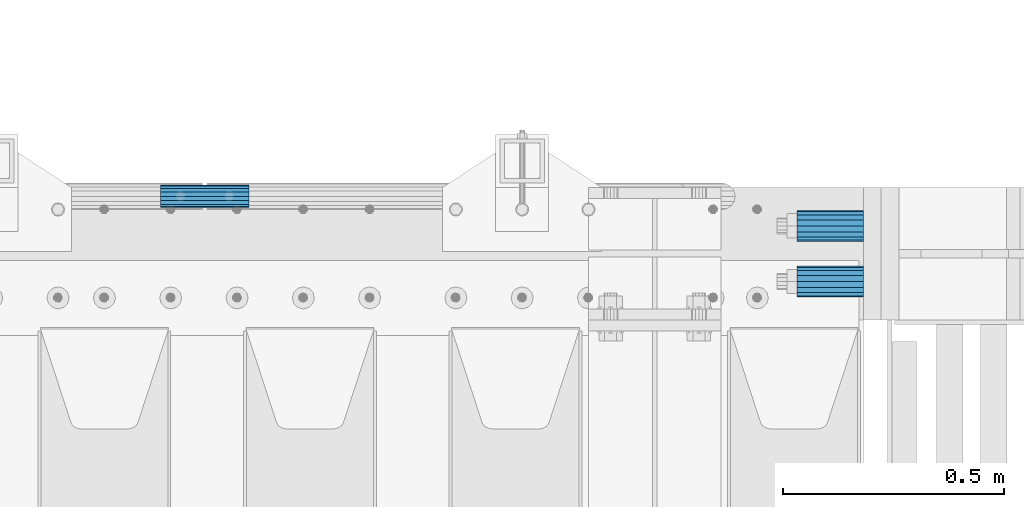
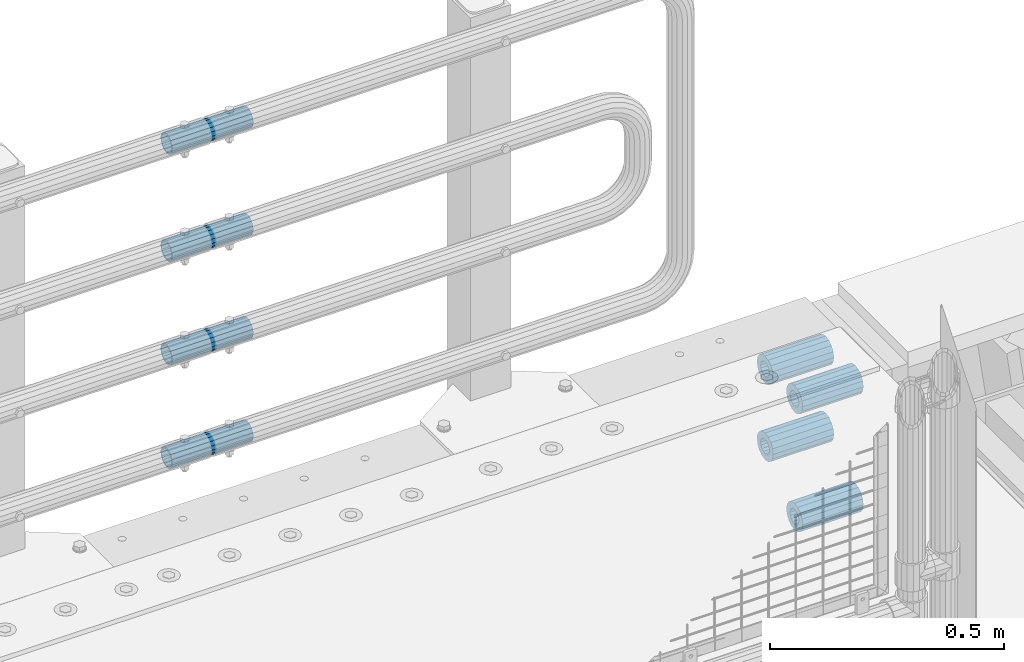
# One storey, part 142 of 208: 8 beams.
"""IFC2X3 building model written with IfcOpenShell, lengths in millimetres."""

from ifc_helpers import new_model, si_unit, frame, origin_with_axes, place, context, subcontext, project, spatial, faceted_brep, material, type_object, element, save


model = new_model("IFC2X3")

# Units and contexts
model_context = context("Model", 3, precision=1e-05, world=origin_with_axes())
body_context = subcontext(model_context, "Body", "Model", "MODEL_VIEW")
ifc_project = project(units=[si_unit("LENGTHUNIT", "METRE", prefix="MILLI"), si_unit("AREAUNIT", "SQUARE_METRE"), si_unit("VOLUMEUNIT", "CUBIC_METRE"), si_unit("MASSUNIT", "GRAM", prefix="KILO"), si_unit("TIMEUNIT", "SECOND"), si_unit("PLANEANGLEUNIT", "RADIAN"), si_unit("SOLIDANGLEUNIT", "STERADIAN"), si_unit("THERMODYNAMICTEMPERATUREUNIT", "DEGREE_CELSIUS"), si_unit("LUMINOUSINTENSITYUNIT", "LUMEN")], contexts=[model_context])

# Site, building, storey
site_placement = place(None, origin_with_axes())
site = spatial("IfcSite", under=ifc_project, at=site_placement, CompositionType="ELEMENT")
building_placement = place(site_placement, origin_with_axes())
building = spatial("IfcBuilding", under=site, at=building_placement, Name="Standard", CompositionType="ELEMENT")
storey_placement = place(building_placement, origin_with_axes())
storey = spatial("IfcBuildingStorey", under=building, at=storey_placement, Name="Undefined", CompositionType="ELEMENT", Elevation=0.0)

# Beams
ifc_material = material()
beam_type_1 = type_object("IfcBeamType", PredefinedType="NOTDEFINED")
beam_1_placement = place(storey_placement, frame((-25783.0, 6063.0, -84.0000000000001), z_axis=(0.0, 0.0, 1.0), x_axis=(1.0, 0.0, 0.0)))
element("IfcBeam", 1, at=beam_1_placement, inside=storey, type_object=beam_type_1, material=ifc_material, context=body_context, shape_type="Brep", body=[
    faceted_brep([(-1.3120632047503e-07, -18.9999999995496, -6.26459950581193e-09), (0.0, -17.5537111177146, 7.27098521493672), (150.0, -17.5537111177146, 7.27098521493672), (150.0, -19.0, 0.0), (0.0, -13.4350288425444, 13.4350288425444), (150.0, -13.4350288425444, 13.4350288425444), (0.0, -7.2709852149369, 17.5537111177144), (150.0, -7.2709852149369, 17.5537111177144), (-6.33906438451959e-09, 4.50199877377599e-10, 18.9999999937354), (150.0, 0.0, 19.0), (0.0, 7.2709852149369, 17.5537111177144), (150.0, 7.2709852149369, 17.5537111177144), (0.0, 13.4350288425444, 13.4350288425444), (150.0, 13.4350288425444, 13.4350288425444), (0.0, 17.5537111177146, 7.2709852149367), (150.0, 17.5537111177146, 7.2709852149367), (1.33208345687308e-07, 19.0000000004507, -6.26459950581193e-09), (150.0, 19.0, 0.0), (0.0, 17.5537111177146, -7.2709852149367), (150.0, 17.5537111177146, -7.2709852149367), (0.0, 13.4350288425444, -13.4350288425444), (150.0, 13.4350288425444, -13.4350288425444), (0.0, 7.2709852149369, -17.5537111177144), (150.0, 7.2709852149369, -17.5537111177144), (8.34120328363497e-09, 4.50427251053043e-10, -19.0000000062646), (150.0, 0.0, -19.0), (0.0, -7.2709852149369, -17.5537111177144), (150.0, -7.2709852149369, -17.5537111177144), (0.0, -13.4350288425444, -13.4350288425444), (150.0, -13.4350288425444, -13.4350288425444), (0.0, -17.5537111177146, -7.2709852149367), (150.0, -17.5537111177146, -7.2709852149367), (0.0, -35.0, 0.0), (-3.63797880709171e-12, -32.335783637895, -13.3939201327782), (150.0, -32.335783637895, -13.3939201327782), (150.0, -35.0, 0.0), (0.0, -24.7487373415292, -24.7487373415291), (150.0, -24.7487373415293, -24.7487373415292), (0.0, -13.3939201327781, -32.335783637895), (150.0, -13.393920132778, -32.335783637895), (0.0, 0.0, -35.0), (150.0, 0.0, -35.0), (0.0, 13.3939201327782, -32.335783637895), (150.0, 13.393920132778, -32.335783637895), (0.0, 24.7487373415292, -24.7487373415291), (150.0, 24.7487373415293, -24.7487373415292), (-3.63797880709171e-12, 32.335783637895, -13.3939201327782), (150.0, 32.335783637895, -13.3939201327781), (0.0, 35.0, 0.0), (150.0, 35.0, 0.0), (0.0, 32.335783637895, 13.3939201327781), (150.0, 32.335783637895, 13.3939201327781), (0.0, 24.7487373415292, 24.748737341529), (150.0, 24.7487373415293, 24.7487373415292), (0.0, 13.3939201327781, 32.335783637895), (150.0, 13.393920132778, 32.335783637895), (-3.63797880709171e-12, 0.0, 35.0), (150.0, 0.0, 35.0), (0.0, -13.3939201327781, 32.335783637895), (150.0, -13.393920132778, 32.335783637895), (0.0, -24.7487373415292, 24.748737341529), (150.0, -24.7487373415293, 24.7487373415292), (0.0, -32.335783637895, 13.3939201327781), (150.0, -32.335783637895, 13.3939201327781)], [[[0, 1, 2, 3]], [[1, 4, 5, 2]], [[4, 6, 7, 5]], [[6, 8, 9, 7]], [[8, 10, 11, 9]], [[10, 12, 13, 11]], [[12, 14, 15, 13]], [[14, 16, 17, 15]], [[16, 18, 19, 17]], [[18, 20, 21, 19]], [[20, 22, 23, 21]], [[22, 24, 25, 23]], [[24, 26, 27, 25]], [[26, 28, 29, 27]], [[28, 30, 31, 29]], [[30, 0, 3, 31]], [[32, 33, 34, 35]], [[33, 36, 37, 34]], [[36, 38, 39, 37]], [[38, 40, 41, 39]], [[40, 42, 43, 41]], [[42, 44, 45, 43]], [[44, 46, 47, 45]], [[46, 48, 49, 47]], [[48, 50, 51, 49]], [[50, 52, 53, 51]], [[52, 54, 55, 53]], [[54, 56, 57, 55]], [[56, 58, 59, 57]], [[58, 60, 61, 59]], [[60, 62, 63, 61]], [[62, 32, 35, 63]], [[37, 39, 41, 43, 45, 47, 49, 51, 53, 55, 57, 59, 61, 63, 35, 34], [5, 7, 9, 11, 13, 15, 17, 19, 21, 23, 25, 27, 29, 31, 3, 2]], [[62, 60, 58, 56, 54, 52, 50, 48, 46, 44, 42, 40, 38, 36, 33, 32], [30, 28, 26, 24, 22, 20, 18, 16, 14, 12, 10, 8, 6, 4, 1, 0]]]),
])
beam_2_placement = place(storey_placement, frame((-25783.0, 5937.0, -84.0000000000001), z_axis=(0.0, 0.0, 1.0), x_axis=(1.0, 0.0, 0.0)))
element("IfcBeam", 2, at=beam_2_placement, inside=storey, type_object=beam_type_1, material=ifc_material, context=body_context, shape_type="Brep", body=[
    faceted_brep([(-1.3120632047503e-07, -18.9999999995496, -6.26459950581193e-09), (0.0, -17.5537111177146, 7.27098521493672), (150.0, -17.5537111177146, 7.27098521493672), (150.0, -19.0, 0.0), (0.0, -13.4350288425444, 13.4350288425444), (150.0, -13.4350288425444, 13.4350288425444), (0.0, -7.2709852149369, 17.5537111177144), (150.0, -7.2709852149369, 17.5537111177144), (-6.33906438451959e-09, 4.50199877377599e-10, 18.9999999937354), (150.0, 0.0, 19.0), (0.0, 7.2709852149369, 17.5537111177144), (150.0, 7.2709852149369, 17.5537111177144), (0.0, 13.4350288425444, 13.4350288425444), (150.0, 13.4350288425444, 13.4350288425444), (0.0, 17.5537111177146, 7.2709852149367), (150.0, 17.5537111177146, 7.2709852149367), (1.33208345687308e-07, 19.0000000004507, -6.26459950581193e-09), (150.0, 19.0, 0.0), (0.0, 17.5537111177146, -7.2709852149367), (150.0, 17.5537111177146, -7.2709852149367), (0.0, 13.4350288425444, -13.4350288425444), (150.0, 13.4350288425444, -13.4350288425444), (0.0, 7.2709852149369, -17.5537111177144), (150.0, 7.2709852149369, -17.5537111177144), (8.34120328363497e-09, 4.50427251053043e-10, -19.0000000062646), (150.0, 0.0, -19.0), (0.0, -7.2709852149369, -17.5537111177144), (150.0, -7.2709852149369, -17.5537111177144), (0.0, -13.4350288425444, -13.4350288425444), (150.0, -13.4350288425444, -13.4350288425444), (0.0, -17.5537111177146, -7.2709852149367), (150.0, -17.5537111177146, -7.2709852149367), (0.0, -35.0, 0.0), (-3.63797880709171e-12, -32.335783637895, -13.3939201327782), (150.0, -32.335783637895, -13.3939201327782), (150.0, -35.0, 0.0), (0.0, -24.7487373415292, -24.7487373415291), (150.0, -24.7487373415293, -24.7487373415292), (0.0, -13.3939201327781, -32.335783637895), (150.0, -13.393920132778, -32.335783637895), (0.0, 0.0, -35.0), (150.0, 0.0, -35.0), (0.0, 13.3939201327782, -32.335783637895), (150.0, 13.393920132778, -32.335783637895), (0.0, 24.7487373415292, -24.7487373415291), (150.0, 24.7487373415293, -24.7487373415292), (-3.63797880709171e-12, 32.335783637895, -13.3939201327782), (150.0, 32.335783637895, -13.3939201327781), (0.0, 35.0, 0.0), (150.0, 35.0, 0.0), (0.0, 32.335783637895, 13.3939201327781), (150.0, 32.335783637895, 13.3939201327781), (0.0, 24.7487373415292, 24.748737341529), (150.0, 24.7487373415293, 24.7487373415292), (0.0, 13.3939201327781, 32.335783637895), (150.0, 13.393920132778, 32.335783637895), (-3.63797880709171e-12, 0.0, 35.0), (150.0, 0.0, 35.0), (0.0, -13.3939201327781, 32.335783637895), (150.0, -13.393920132778, 32.335783637895), (0.0, -24.7487373415292, 24.748737341529), (150.0, -24.7487373415293, 24.7487373415292), (0.0, -32.335783637895, 13.3939201327781), (150.0, -32.335783637895, 13.3939201327781)], [[[0, 1, 2, 3]], [[1, 4, 5, 2]], [[4, 6, 7, 5]], [[6, 8, 9, 7]], [[8, 10, 11, 9]], [[10, 12, 13, 11]], [[12, 14, 15, 13]], [[14, 16, 17, 15]], [[16, 18, 19, 17]], [[18, 20, 21, 19]], [[20, 22, 23, 21]], [[22, 24, 25, 23]], [[24, 26, 27, 25]], [[26, 28, 29, 27]], [[28, 30, 31, 29]], [[30, 0, 3, 31]], [[32, 33, 34, 35]], [[33, 36, 37, 34]], [[36, 38, 39, 37]], [[38, 40, 41, 39]], [[40, 42, 43, 41]], [[42, 44, 45, 43]], [[44, 46, 47, 45]], [[46, 48, 49, 47]], [[48, 50, 51, 49]], [[50, 52, 53, 51]], [[52, 54, 55, 53]], [[54, 56, 57, 55]], [[56, 58, 59, 57]], [[58, 60, 61, 59]], [[60, 62, 63, 61]], [[62, 32, 35, 63]], [[37, 39, 41, 43, 45, 47, 49, 51, 53, 55, 57, 59, 61, 63, 35, 34], [5, 7, 9, 11, 13, 15, 17, 19, 21, 23, 25, 27, 29, 31, 3, 2]], [[62, 60, 58, 56, 54, 52, 50, 48, 46, 44, 42, 40, 38, 36, 33, 32], [30, 28, 26, 24, 22, 20, 18, 16, 14, 12, 10, 8, 6, 4, 1, 0]]]),
])
beam_3_placement = place(storey_placement, frame((-25783.0, 5937.0, -392.0), z_axis=(0.0, 0.0, 1.0), x_axis=(1.0, 0.0, 0.0)))
element("IfcBeam", 3, at=beam_3_placement, inside=storey, type_object=beam_type_1, material=ifc_material, context=body_context, shape_type="Brep", body=[
    faceted_brep([(-1.3120632047503e-07, -18.9999999995496, -6.26459950581193e-09), (0.0, -17.5537111177146, 7.27098521493672), (150.0, -17.5537111177146, 7.27098521493672), (150.0, -19.0, 0.0), (0.0, -13.4350288425444, 13.4350288425444), (150.0, -13.4350288425444, 13.4350288425444), (0.0, -7.2709852149369, 17.5537111177144), (150.0, -7.2709852149369, 17.5537111177144), (-6.33906438451959e-09, 4.50199877377599e-10, 18.9999999937354), (150.0, 0.0, 19.0), (0.0, 7.2709852149369, 17.5537111177144), (150.0, 7.2709852149369, 17.5537111177144), (0.0, 13.4350288425444, 13.4350288425444), (150.0, 13.4350288425444, 13.4350288425444), (0.0, 17.5537111177146, 7.2709852149367), (150.0, 17.5537111177146, 7.2709852149367), (1.33208345687308e-07, 19.0000000004507, -6.26459950581193e-09), (150.0, 19.0, 0.0), (0.0, 17.5537111177146, -7.2709852149367), (150.0, 17.5537111177146, -7.2709852149367), (0.0, 13.4350288425444, -13.4350288425444), (150.0, 13.4350288425444, -13.4350288425444), (0.0, 7.2709852149369, -17.5537111177144), (150.0, 7.2709852149369, -17.5537111177144), (8.34120328363497e-09, 4.50427251053043e-10, -19.0000000062646), (150.0, 0.0, -19.0), (0.0, -7.2709852149369, -17.5537111177144), (150.0, -7.2709852149369, -17.5537111177144), (0.0, -13.4350288425444, -13.4350288425444), (150.0, -13.4350288425444, -13.4350288425444), (0.0, -17.5537111177146, -7.2709852149367), (150.0, -17.5537111177146, -7.2709852149367), (0.0, -35.0, 0.0), (-3.63797880709171e-12, -32.335783637895, -13.3939201327782), (150.0, -32.335783637895, -13.3939201327782), (150.0, -35.0, 0.0), (0.0, -24.7487373415292, -24.7487373415291), (150.0, -24.7487373415293, -24.7487373415292), (0.0, -13.3939201327781, -32.335783637895), (150.0, -13.393920132778, -32.335783637895), (0.0, 0.0, -35.0), (150.0, 0.0, -35.0), (0.0, 13.3939201327782, -32.335783637895), (150.0, 13.393920132778, -32.335783637895), (0.0, 24.7487373415292, -24.7487373415291), (150.0, 24.7487373415293, -24.7487373415292), (-3.63797880709171e-12, 32.335783637895, -13.3939201327782), (150.0, 32.335783637895, -13.3939201327781), (0.0, 35.0, 0.0), (150.0, 35.0, 0.0), (0.0, 32.335783637895, 13.3939201327781), (150.0, 32.335783637895, 13.3939201327781), (0.0, 24.7487373415292, 24.748737341529), (150.0, 24.7487373415293, 24.7487373415292), (0.0, 13.3939201327781, 32.335783637895), (150.0, 13.393920132778, 32.335783637895), (-3.63797880709171e-12, 0.0, 35.0), (150.0, 0.0, 35.0), (0.0, -13.3939201327781, 32.335783637895), (150.0, -13.393920132778, 32.335783637895), (0.0, -24.7487373415292, 24.748737341529), (150.0, -24.7487373415293, 24.7487373415292), (0.0, -32.335783637895, 13.3939201327781), (150.0, -32.335783637895, 13.3939201327781)], [[[0, 1, 2, 3]], [[1, 4, 5, 2]], [[4, 6, 7, 5]], [[6, 8, 9, 7]], [[8, 10, 11, 9]], [[10, 12, 13, 11]], [[12, 14, 15, 13]], [[14, 16, 17, 15]], [[16, 18, 19, 17]], [[18, 20, 21, 19]], [[20, 22, 23, 21]], [[22, 24, 25, 23]], [[24, 26, 27, 25]], [[26, 28, 29, 27]], [[28, 30, 31, 29]], [[30, 0, 3, 31]], [[32, 33, 34, 35]], [[33, 36, 37, 34]], [[36, 38, 39, 37]], [[38, 40, 41, 39]], [[40, 42, 43, 41]], [[42, 44, 45, 43]], [[44, 46, 47, 45]], [[46, 48, 49, 47]], [[48, 50, 51, 49]], [[50, 52, 53, 51]], [[52, 54, 55, 53]], [[54, 56, 57, 55]], [[56, 58, 59, 57]], [[58, 60, 61, 59]], [[60, 62, 63, 61]], [[62, 32, 35, 63]], [[37, 39, 41, 43, 45, 47, 49, 51, 53, 55, 57, 59, 61, 63, 35, 34], [5, 7, 9, 11, 13, 15, 17, 19, 21, 23, 25, 27, 29, 31, 3, 2]], [[62, 60, 58, 56, 54, 52, 50, 48, 46, 44, 42, 40, 38, 36, 33, 32], [30, 28, 26, 24, 22, 20, 18, 16, 14, 12, 10, 8, 6, 4, 1, 0]]]),
])
beam_4_placement = place(storey_placement, frame((-25783.0, 6063.0, -285.0), z_axis=(0.0, 0.0, 1.0), x_axis=(1.0, 0.0, 0.0)))
element("IfcBeam", 4, at=beam_4_placement, inside=storey, type_object=beam_type_1, material=ifc_material, context=body_context, shape_type="Brep", body=[
    faceted_brep([(-1.3120632047503e-07, -18.9999999995496, -6.26459950581193e-09), (0.0, -17.5537111177146, 7.27098521493672), (150.0, -17.5537111177146, 7.27098521493672), (150.0, -19.0, 0.0), (0.0, -13.4350288425444, 13.4350288425444), (150.0, -13.4350288425444, 13.4350288425444), (0.0, -7.2709852149369, 17.5537111177144), (150.0, -7.2709852149369, 17.5537111177144), (-6.33906438451959e-09, 4.50199877377599e-10, 18.9999999937354), (150.0, 0.0, 19.0), (0.0, 7.2709852149369, 17.5537111177144), (150.0, 7.2709852149369, 17.5537111177144), (0.0, 13.4350288425444, 13.4350288425444), (150.0, 13.4350288425444, 13.4350288425444), (0.0, 17.5537111177146, 7.2709852149367), (150.0, 17.5537111177146, 7.2709852149367), (1.33208345687308e-07, 19.0000000004507, -6.26459950581193e-09), (150.0, 19.0, 0.0), (0.0, 17.5537111177146, -7.2709852149367), (150.0, 17.5537111177146, -7.2709852149367), (0.0, 13.4350288425444, -13.4350288425444), (150.0, 13.4350288425444, -13.4350288425444), (0.0, 7.2709852149369, -17.5537111177144), (150.0, 7.2709852149369, -17.5537111177144), (8.34120328363497e-09, 4.50427251053043e-10, -19.0000000062646), (150.0, 0.0, -19.0), (0.0, -7.2709852149369, -17.5537111177144), (150.0, -7.2709852149369, -17.5537111177144), (0.0, -13.4350288425444, -13.4350288425444), (150.0, -13.4350288425444, -13.4350288425444), (0.0, -17.5537111177146, -7.2709852149367), (150.0, -17.5537111177146, -7.2709852149367), (0.0, -35.0, 0.0), (-3.63797880709171e-12, -32.335783637895, -13.3939201327782), (150.0, -32.335783637895, -13.3939201327782), (150.0, -35.0, 0.0), (0.0, -24.7487373415292, -24.7487373415291), (150.0, -24.7487373415293, -24.7487373415292), (0.0, -13.3939201327781, -32.335783637895), (150.0, -13.393920132778, -32.335783637895), (0.0, 0.0, -35.0), (150.0, 0.0, -35.0), (0.0, 13.3939201327782, -32.335783637895), (150.0, 13.393920132778, -32.335783637895), (0.0, 24.7487373415292, -24.7487373415291), (150.0, 24.7487373415293, -24.7487373415292), (-3.63797880709171e-12, 32.335783637895, -13.3939201327782), (150.0, 32.335783637895, -13.3939201327781), (0.0, 35.0, 0.0), (150.0, 35.0, 0.0), (0.0, 32.335783637895, 13.3939201327781), (150.0, 32.335783637895, 13.3939201327781), (0.0, 24.7487373415292, 24.748737341529), (150.0, 24.7487373415293, 24.7487373415292), (0.0, 13.3939201327781, 32.335783637895), (150.0, 13.393920132778, 32.335783637895), (-3.63797880709171e-12, 0.0, 35.0), (150.0, 0.0, 35.0), (0.0, -13.3939201327781, 32.335783637895), (150.0, -13.393920132778, 32.335783637895), (0.0, -24.7487373415292, 24.748737341529), (150.0, -24.7487373415293, 24.7487373415292), (0.0, -32.335783637895, 13.3939201327781), (150.0, -32.335783637895, 13.3939201327781)], [[[0, 1, 2, 3]], [[1, 4, 5, 2]], [[4, 6, 7, 5]], [[6, 8, 9, 7]], [[8, 10, 11, 9]], [[10, 12, 13, 11]], [[12, 14, 15, 13]], [[14, 16, 17, 15]], [[16, 18, 19, 17]], [[18, 20, 21, 19]], [[20, 22, 23, 21]], [[22, 24, 25, 23]], [[24, 26, 27, 25]], [[26, 28, 29, 27]], [[28, 30, 31, 29]], [[30, 0, 3, 31]], [[32, 33, 34, 35]], [[33, 36, 37, 34]], [[36, 38, 39, 37]], [[38, 40, 41, 39]], [[40, 42, 43, 41]], [[42, 44, 45, 43]], [[44, 46, 47, 45]], [[46, 48, 49, 47]], [[48, 50, 51, 49]], [[50, 52, 53, 51]], [[52, 54, 55, 53]], [[54, 56, 57, 55]], [[56, 58, 59, 57]], [[58, 60, 61, 59]], [[60, 62, 63, 61]], [[62, 32, 35, 63]], [[37, 39, 41, 43, 45, 47, 49, 51, 53, 55, 57, 59, 61, 63, 35, 34], [5, 7, 9, 11, 13, 15, 17, 19, 21, 23, 25, 27, 29, 31, 3, 2]], [[62, 60, 58, 56, 54, 52, 50, 48, 46, 44, 42, 40, 38, 36, 33, 32], [30, 28, 26, 24, 22, 20, 18, 16, 14, 12, 10, 8, 6, 4, 1, 0]]]),
])
beam_type_2 = type_object("IfcBeamType", PredefinedType="NOTDEFINED")
beam_5_placement = place(storey_placement, frame((-27223.0024970001, 6129.8500000004, 419.849999999725), z_axis=(0.0, 0.0, 1.0), x_axis=(1.0, 0.0, 0.0)))
element("IfcBeam", 5, at=beam_5_placement, inside=storey, type_object=beam_type_2, material=ifc_material, context=body_context, shape_type="Brep", body=[
    faceted_brep([(0.0, -21.8999999999996, 0.0), (0.0, -20.2329617619971, 8.38076716879547), (200.0, -20.2329617619971, 8.38076716879547), (200.0, -21.8999999999996, 0.0), (0.0, -15.4856385079856, 15.4856385079854), (200.0, -15.4856385079856, 15.4856385079854), (0.0, -8.3807671687955, 20.2329617619972), (200.0, -8.3807671687955, 20.2329617619972), (0.0, 0.0, 21.9), (200.0, 0.0, 21.9), (0.0, 8.3807671687955, 20.2329617619972), (200.0, 8.3807671687955, 20.2329617619972), (0.0, 15.4856385079856, 15.4856385079854), (200.0, 15.4856385079856, 15.4856385079854), (0.0, 20.2329617619971, 8.38076716879547), (200.0, 20.2329617619971, 8.38076716879547), (0.0, 21.8999999999996, 0.0), (200.0, 21.8999999999996, 0.0), (0.0, 20.2329617619971, -8.38076716879547), (200.0, 20.2329617619971, -8.38076716879547), (0.0, 15.4856385079856, -15.4856385079854), (200.0, 15.4856385079856, -15.4856385079854), (0.0, 8.3807671687955, -20.2329617619972), (200.0, 8.3807671687955, -20.2329617619972), (0.0, 0.0, -21.9), (200.0, 0.0, -21.9), (0.0, -8.3807671687955, -20.2329617619972), (200.0, -8.3807671687955, -20.2329617619972), (0.0, -15.4856385079856, -15.4856385079854), (200.0, -15.4856385079856, -15.4856385079854), (0.0, -20.2329617619971, -8.38076716879547), (200.0, -20.2329617619971, -8.38076716879547), (0.0, -25.5, 0.0), (0.0, -23.5589280790382, -9.7584275253098), (200.0, -23.5589280790382, -9.7584275253098), (200.0, -25.5, 0.0), (0.0, -18.0312229202573, -18.031222920257), (200.0, -18.0312229202573, -18.031222920257), (0.0, -9.75842752530934, -23.5589280790378), (200.0, -9.75842752530934, -23.5589280790378), (0.0, 0.0, -25.5), (200.0, 0.0, -25.5), (0.0, 9.75842752531025, -23.5589280790378), (200.0, 9.75842752531025, -23.5589280790378), (0.0, 18.0312229202573, -18.031222920257), (200.0, 18.0312229202573, -18.031222920257), (0.0, 23.5589280790382, -9.7584275253098), (200.0, 23.5589280790382, -9.7584275253098), (0.0, 25.5, 0.0), (200.0, 25.5, 0.0), (0.0, 23.5589280790382, 9.7584275253098), (200.0, 23.5589280790382, 9.7584275253098), (0.0, 18.0312229202573, 18.031222920257), (200.0, 18.0312229202573, 18.031222920257), (0.0, 9.75842752530934, 23.5589280790378), (200.0, 9.75842752530934, 23.5589280790378), (0.0, 0.0, 25.5), (200.0, 0.0, 25.5), (0.0, -9.75842752530934, 23.5589280790378), (200.0, -9.75842752530934, 23.5589280790378), (0.0, -18.0312229202573, 18.031222920257), (200.0, -18.0312229202573, 18.031222920257), (0.0, -23.5589280790382, 9.7584275253098), (200.0, -23.5589280790382, 9.7584275253098)], [[[0, 1, 2, 3]], [[1, 4, 5, 2]], [[4, 6, 7, 5]], [[6, 8, 9, 7]], [[8, 10, 11, 9]], [[10, 12, 13, 11]], [[12, 14, 15, 13]], [[14, 16, 17, 15]], [[16, 18, 19, 17]], [[18, 20, 21, 19]], [[20, 22, 23, 21]], [[22, 24, 25, 23]], [[24, 26, 27, 25]], [[26, 28, 29, 27]], [[28, 30, 31, 29]], [[30, 0, 3, 31]], [[32, 33, 34, 35]], [[33, 36, 37, 34]], [[36, 38, 39, 37]], [[38, 40, 41, 39]], [[40, 42, 43, 41]], [[42, 44, 45, 43]], [[44, 46, 47, 45]], [[46, 48, 49, 47]], [[48, 50, 51, 49]], [[50, 52, 53, 51]], [[52, 54, 55, 53]], [[54, 56, 57, 55]], [[56, 58, 59, 57]], [[58, 60, 61, 59]], [[60, 62, 63, 61]], [[62, 32, 35, 63]], [[37, 39, 41, 43, 45, 47, 49, 51, 53, 55, 57, 59, 61, 63, 35, 34], [5, 7, 9, 11, 13, 15, 17, 19, 21, 23, 25, 27, 29, 31, 3, 2]], [[62, 60, 58, 56, 54, 52, 50, 48, 46, 44, 42, 40, 38, 36, 33, 32], [30, 28, 26, 24, 22, 20, 18, 16, 14, 12, 10, 8, 6, 4, 1, 0]]]),
])
beam_6_placement = place(storey_placement, frame((-27223.0024970001, 6129.8500000004, 149.849999999725), z_axis=(0.0, 0.0, 1.0), x_axis=(1.0, 0.0, 0.0)))
element("IfcBeam", 6, at=beam_6_placement, inside=storey, type_object=beam_type_2, material=ifc_material, context=body_context, shape_type="Brep", body=[
    faceted_brep([(0.0, -21.8999999999996, 0.0), (0.0, -20.2329617619971, 8.38076716879547), (200.0, -20.2329617619971, 8.38076716879547), (200.0, -21.8999999999996, 0.0), (0.0, -15.4856385079856, 15.4856385079854), (200.0, -15.4856385079856, 15.4856385079854), (0.0, -8.3807671687955, 20.2329617619972), (200.0, -8.3807671687955, 20.2329617619972), (0.0, 0.0, 21.9), (200.0, 0.0, 21.9), (0.0, 8.3807671687955, 20.2329617619972), (200.0, 8.3807671687955, 20.2329617619972), (0.0, 15.4856385079856, 15.4856385079854), (200.0, 15.4856385079856, 15.4856385079854), (0.0, 20.2329617619971, 8.38076716879547), (200.0, 20.2329617619971, 8.38076716879547), (0.0, 21.8999999999996, 0.0), (200.0, 21.8999999999996, 0.0), (0.0, 20.2329617619971, -8.38076716879547), (200.0, 20.2329617619971, -8.38076716879547), (0.0, 15.4856385079856, -15.4856385079854), (200.0, 15.4856385079856, -15.4856385079854), (0.0, 8.3807671687955, -20.2329617619972), (200.0, 8.3807671687955, -20.2329617619972), (0.0, 0.0, -21.9), (200.0, 0.0, -21.9), (0.0, -8.3807671687955, -20.2329617619972), (200.0, -8.3807671687955, -20.2329617619972), (0.0, -15.4856385079856, -15.4856385079854), (200.0, -15.4856385079856, -15.4856385079854), (0.0, -20.2329617619971, -8.38076716879547), (200.0, -20.2329617619971, -8.38076716879547), (0.0, -25.5, 0.0), (0.0, -23.5589280790382, -9.7584275253098), (200.0, -23.5589280790382, -9.7584275253098), (200.0, -25.5, 0.0), (0.0, -18.0312229202573, -18.031222920257), (200.0, -18.0312229202573, -18.031222920257), (0.0, -9.75842752530934, -23.5589280790378), (200.0, -9.75842752530934, -23.5589280790378), (0.0, 0.0, -25.5), (200.0, 0.0, -25.5), (0.0, 9.75842752531025, -23.5589280790378), (200.0, 9.75842752531025, -23.5589280790378), (0.0, 18.0312229202573, -18.031222920257), (200.0, 18.0312229202573, -18.031222920257), (0.0, 23.5589280790382, -9.7584275253098), (200.0, 23.5589280790382, -9.7584275253098), (0.0, 25.5, 0.0), (200.0, 25.5, 0.0), (0.0, 23.5589280790382, 9.7584275253098), (200.0, 23.5589280790382, 9.7584275253098), (0.0, 18.0312229202573, 18.031222920257), (200.0, 18.0312229202573, 18.031222920257), (0.0, 9.75842752530934, 23.5589280790378), (200.0, 9.75842752530934, 23.5589280790378), (0.0, 0.0, 25.5), (200.0, 0.0, 25.5), (0.0, -9.75842752530934, 23.5589280790378), (200.0, -9.75842752530934, 23.5589280790378), (0.0, -18.0312229202573, 18.031222920257), (200.0, -18.0312229202573, 18.031222920257), (0.0, -23.5589280790382, 9.7584275253098), (200.0, -23.5589280790382, 9.7584275253098)], [[[0, 1, 2, 3]], [[1, 4, 5, 2]], [[4, 6, 7, 5]], [[6, 8, 9, 7]], [[8, 10, 11, 9]], [[10, 12, 13, 11]], [[12, 14, 15, 13]], [[14, 16, 17, 15]], [[16, 18, 19, 17]], [[18, 20, 21, 19]], [[20, 22, 23, 21]], [[22, 24, 25, 23]], [[24, 26, 27, 25]], [[26, 28, 29, 27]], [[28, 30, 31, 29]], [[30, 0, 3, 31]], [[32, 33, 34, 35]], [[33, 36, 37, 34]], [[36, 38, 39, 37]], [[38, 40, 41, 39]], [[40, 42, 43, 41]], [[42, 44, 45, 43]], [[44, 46, 47, 45]], [[46, 48, 49, 47]], [[48, 50, 51, 49]], [[50, 52, 53, 51]], [[52, 54, 55, 53]], [[54, 56, 57, 55]], [[56, 58, 59, 57]], [[58, 60, 61, 59]], [[60, 62, 63, 61]], [[62, 32, 35, 63]], [[37, 39, 41, 43, 45, 47, 49, 51, 53, 55, 57, 59, 61, 63, 35, 34], [5, 7, 9, 11, 13, 15, 17, 19, 21, 23, 25, 27, 29, 31, 3, 2]], [[62, 60, 58, 56, 54, 52, 50, 48, 46, 44, 42, 40, 38, 36, 33, 32], [30, 28, 26, 24, 22, 20, 18, 16, 14, 12, 10, 8, 6, 4, 1, 0]]]),
])
beam_7_placement = place(storey_placement, frame((-27223.0024970001, 6129.8500000004, 689.849999999725), z_axis=(0.0, 0.0, 1.0), x_axis=(1.0, 0.0, 0.0)))
element("IfcBeam", 7, at=beam_7_placement, inside=storey, type_object=beam_type_2, material=ifc_material, context=body_context, shape_type="Brep", body=[
    faceted_brep([(0.0, -21.8999999999996, 0.0), (0.0, -20.2329617619971, 8.38076716879547), (200.0, -20.2329617619971, 8.38076716879547), (200.0, -21.8999999999996, 0.0), (0.0, -15.4856385079856, 15.4856385079854), (200.0, -15.4856385079856, 15.4856385079854), (0.0, -8.3807671687955, 20.2329617619972), (200.0, -8.3807671687955, 20.2329617619972), (0.0, 0.0, 21.9), (200.0, 0.0, 21.9), (0.0, 8.3807671687955, 20.2329617619972), (200.0, 8.3807671687955, 20.2329617619972), (0.0, 15.4856385079856, 15.4856385079854), (200.0, 15.4856385079856, 15.4856385079854), (0.0, 20.2329617619971, 8.38076716879547), (200.0, 20.2329617619971, 8.38076716879547), (0.0, 21.8999999999996, 0.0), (200.0, 21.8999999999996, 0.0), (0.0, 20.2329617619971, -8.38076716879547), (200.0, 20.2329617619971, -8.38076716879547), (0.0, 15.4856385079856, -15.4856385079854), (200.0, 15.4856385079856, -15.4856385079854), (0.0, 8.3807671687955, -20.2329617619972), (200.0, 8.3807671687955, -20.2329617619972), (0.0, 0.0, -21.9), (200.0, 0.0, -21.9), (0.0, -8.3807671687955, -20.2329617619972), (200.0, -8.3807671687955, -20.2329617619972), (0.0, -15.4856385079856, -15.4856385079854), (200.0, -15.4856385079856, -15.4856385079854), (0.0, -20.2329617619971, -8.38076716879547), (200.0, -20.2329617619971, -8.38076716879547), (0.0, -25.5, 0.0), (0.0, -23.5589280790382, -9.7584275253098), (200.0, -23.5589280790382, -9.7584275253098), (200.0, -25.5, 0.0), (0.0, -18.0312229202573, -18.031222920257), (200.0, -18.0312229202573, -18.031222920257), (0.0, -9.75842752530934, -23.5589280790378), (200.0, -9.75842752530934, -23.5589280790378), (0.0, 0.0, -25.5), (200.0, 0.0, -25.5), (0.0, 9.75842752531025, -23.5589280790378), (200.0, 9.75842752531025, -23.5589280790378), (0.0, 18.0312229202573, -18.031222920257), (200.0, 18.0312229202573, -18.031222920257), (0.0, 23.5589280790382, -9.7584275253098), (200.0, 23.5589280790382, -9.7584275253098), (0.0, 25.5, 0.0), (200.0, 25.5, 0.0), (0.0, 23.5589280790382, 9.7584275253098), (200.0, 23.5589280790382, 9.7584275253098), (0.0, 18.0312229202573, 18.031222920257), (200.0, 18.0312229202573, 18.031222920257), (0.0, 9.75842752530934, 23.5589280790378), (200.0, 9.75842752530934, 23.5589280790378), (0.0, 0.0, 25.5), (200.0, 0.0, 25.5), (0.0, -9.75842752530934, 23.5589280790378), (200.0, -9.75842752530934, 23.5589280790378), (0.0, -18.0312229202573, 18.031222920257), (200.0, -18.0312229202573, 18.031222920257), (0.0, -23.5589280790382, 9.7584275253098), (200.0, -23.5589280790382, 9.7584275253098)], [[[0, 1, 2, 3]], [[1, 4, 5, 2]], [[4, 6, 7, 5]], [[6, 8, 9, 7]], [[8, 10, 11, 9]], [[10, 12, 13, 11]], [[12, 14, 15, 13]], [[14, 16, 17, 15]], [[16, 18, 19, 17]], [[18, 20, 21, 19]], [[20, 22, 23, 21]], [[22, 24, 25, 23]], [[24, 26, 27, 25]], [[26, 28, 29, 27]], [[28, 30, 31, 29]], [[30, 0, 3, 31]], [[32, 33, 34, 35]], [[33, 36, 37, 34]], [[36, 38, 39, 37]], [[38, 40, 41, 39]], [[40, 42, 43, 41]], [[42, 44, 45, 43]], [[44, 46, 47, 45]], [[46, 48, 49, 47]], [[48, 50, 51, 49]], [[50, 52, 53, 51]], [[52, 54, 55, 53]], [[54, 56, 57, 55]], [[56, 58, 59, 57]], [[58, 60, 61, 59]], [[60, 62, 63, 61]], [[62, 32, 35, 63]], [[37, 39, 41, 43, 45, 47, 49, 51, 53, 55, 57, 59, 61, 63, 35, 34], [5, 7, 9, 11, 13, 15, 17, 19, 21, 23, 25, 27, 29, 31, 3, 2]], [[62, 60, 58, 56, 54, 52, 50, 48, 46, 44, 42, 40, 38, 36, 33, 32], [30, 28, 26, 24, 22, 20, 18, 16, 14, 12, 10, 8, 6, 4, 1, 0]]]),
])
beam_8_placement = place(storey_placement, frame((-27223.0024970001, 6129.85000000045, 969.849999999725), z_axis=(0.0, 0.0, 1.0), x_axis=(1.0, 0.0, 0.0)))
element("IfcBeam", 8, at=beam_8_placement, inside=storey, type_object=beam_type_2, material=ifc_material, context=body_context, shape_type="Brep", body=[
    faceted_brep([(0.0, -21.8999999999996, 0.0), (0.0, -20.2329617619971, 8.38076716879547), (200.0, -20.2329617619971, 8.38076716879547), (200.0, -21.8999999999996, 0.0), (0.0, -15.4856385079856, 15.4856385079854), (200.0, -15.4856385079856, 15.4856385079854), (0.0, -8.3807671687955, 20.2329617619972), (200.0, -8.3807671687955, 20.2329617619972), (0.0, 0.0, 21.9), (200.0, 0.0, 21.9), (0.0, 8.3807671687955, 20.2329617619972), (200.0, 8.3807671687955, 20.2329617619972), (0.0, 15.4856385079856, 15.4856385079854), (200.0, 15.4856385079856, 15.4856385079854), (0.0, 20.2329617619971, 8.38076716879547), (200.0, 20.2329617619971, 8.38076716879547), (0.0, 21.8999999999996, 0.0), (200.0, 21.8999999999996, 0.0), (0.0, 20.2329617619971, -8.38076716879547), (200.0, 20.2329617619971, -8.38076716879547), (0.0, 15.4856385079856, -15.4856385079854), (200.0, 15.4856385079856, -15.4856385079854), (0.0, 8.3807671687955, -20.2329617619972), (200.0, 8.3807671687955, -20.2329617619972), (0.0, 0.0, -21.9), (200.0, 0.0, -21.9), (0.0, -8.3807671687955, -20.2329617619972), (200.0, -8.3807671687955, -20.2329617619972), (0.0, -15.4856385079856, -15.4856385079854), (200.0, -15.4856385079856, -15.4856385079854), (0.0, -20.2329617619971, -8.38076716879547), (200.0, -20.2329617619971, -8.38076716879547), (0.0, -25.5, 0.0), (0.0, -23.5589280790382, -9.7584275253098), (200.0, -23.5589280790382, -9.7584275253098), (200.0, -25.5, 0.0), (0.0, -18.0312229202573, -18.031222920257), (200.0, -18.0312229202573, -18.031222920257), (0.0, -9.75842752530934, -23.5589280790378), (200.0, -9.75842752530934, -23.5589280790378), (0.0, 0.0, -25.5), (200.0, 0.0, -25.5), (0.0, 9.75842752531025, -23.5589280790378), (200.0, 9.75842752531025, -23.5589280790378), (0.0, 18.0312229202573, -18.031222920257), (200.0, 18.0312229202573, -18.031222920257), (0.0, 23.5589280790382, -9.7584275253098), (200.0, 23.5589280790382, -9.7584275253098), (0.0, 25.5, 0.0), (200.0, 25.5, 0.0), (0.0, 23.5589280790382, 9.7584275253098), (200.0, 23.5589280790382, 9.7584275253098), (0.0, 18.0312229202573, 18.031222920257), (200.0, 18.0312229202573, 18.031222920257), (0.0, 9.75842752530934, 23.5589280790378), (200.0, 9.75842752530934, 23.5589280790378), (0.0, 0.0, 25.5), (200.0, 0.0, 25.5), (0.0, -9.75842752530934, 23.5589280790378), (200.0, -9.75842752530934, 23.5589280790378), (0.0, -18.0312229202573, 18.031222920257), (200.0, -18.0312229202573, 18.031222920257), (0.0, -23.5589280790382, 9.7584275253098), (200.0, -23.5589280790382, 9.7584275253098)], [[[0, 1, 2, 3]], [[1, 4, 5, 2]], [[4, 6, 7, 5]], [[6, 8, 9, 7]], [[8, 10, 11, 9]], [[10, 12, 13, 11]], [[12, 14, 15, 13]], [[14, 16, 17, 15]], [[16, 18, 19, 17]], [[18, 20, 21, 19]], [[20, 22, 23, 21]], [[22, 24, 25, 23]], [[24, 26, 27, 25]], [[26, 28, 29, 27]], [[28, 30, 31, 29]], [[30, 0, 3, 31]], [[32, 33, 34, 35]], [[33, 36, 37, 34]], [[36, 38, 39, 37]], [[38, 40, 41, 39]], [[40, 42, 43, 41]], [[42, 44, 45, 43]], [[44, 46, 47, 45]], [[46, 48, 49, 47]], [[48, 50, 51, 49]], [[50, 52, 53, 51]], [[52, 54, 55, 53]], [[54, 56, 57, 55]], [[56, 58, 59, 57]], [[58, 60, 61, 59]], [[60, 62, 63, 61]], [[62, 32, 35, 63]], [[37, 39, 41, 43, 45, 47, 49, 51, 53, 55, 57, 59, 61, 63, 35, 34], [5, 7, 9, 11, 13, 15, 17, 19, 21, 23, 25, 27, 29, 31, 3, 2]], [[62, 60, 58, 56, 54, 52, 50, 48, 46, 44, 42, 40, 38, 36, 33, 32], [30, 28, 26, 24, 22, 20, 18, 16, 14, 12, 10, 8, 6, 4, 1, 0]]]),
])

save(model, "model.ifc")
